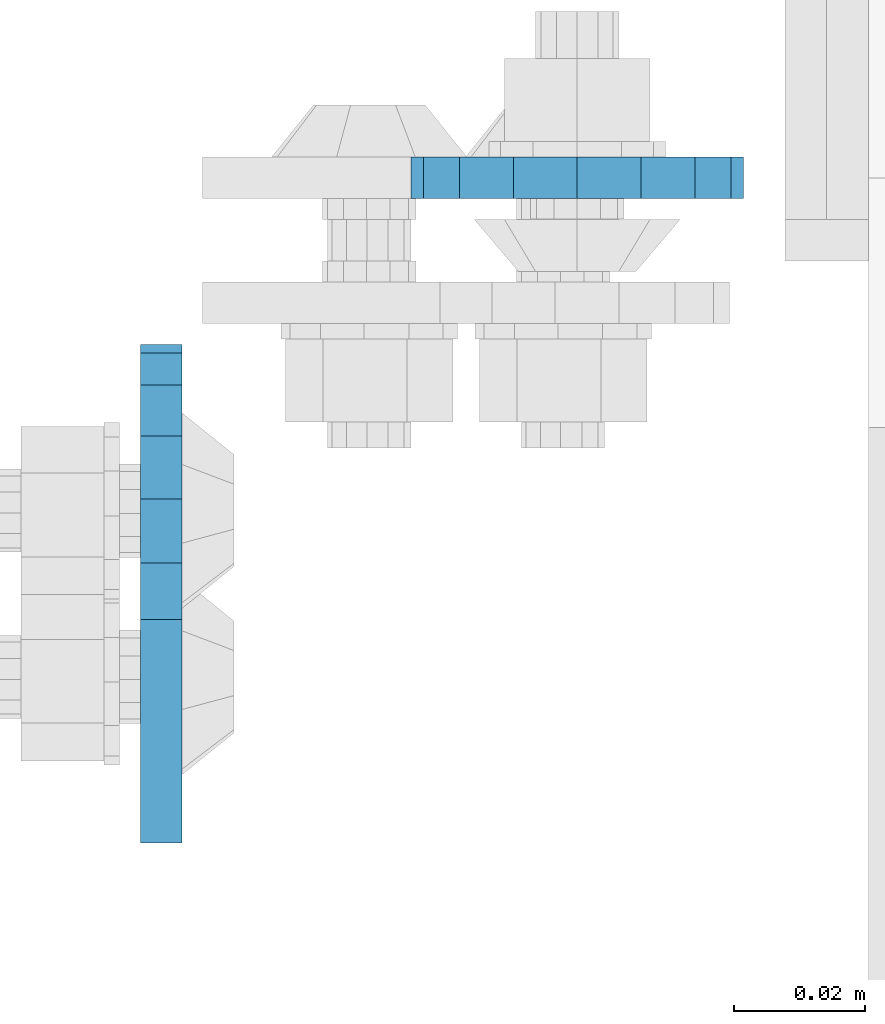
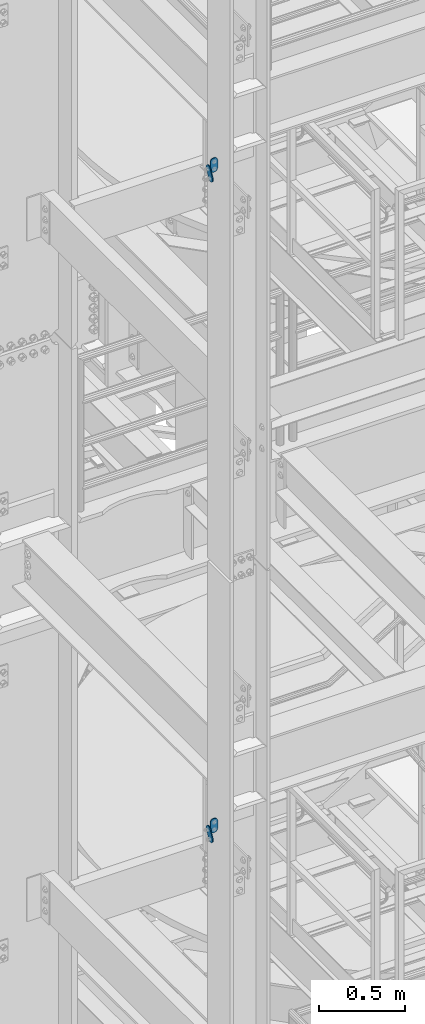
# One storey, part 1419 of 1876: 4 plates, 4 elements without a shape of their own.
"""IFC2X3 building model written with IfcOpenShell, lengths in millimetres."""

from ifc_helpers import new_model, si_unit, frame, origin_with_axes, place, context, subcontext, project, spatial, faceted_brep, material, type_object, element, aggregate, save


model = new_model("IFC2X3")

# Units and contexts
model_context = context("Model", 3, precision=1e-05, world=origin_with_axes())
body_context = subcontext(model_context, "Body", "Model", "MODEL_VIEW")
ifc_project = project(units=[si_unit("LENGTHUNIT", "METRE", prefix="MILLI"), si_unit("AREAUNIT", "SQUARE_METRE"), si_unit("VOLUMEUNIT", "CUBIC_METRE"), si_unit("MASSUNIT", "GRAM", prefix="KILO"), si_unit("TIMEUNIT", "SECOND"), si_unit("PLANEANGLEUNIT", "RADIAN"), si_unit("SOLIDANGLEUNIT", "STERADIAN"), si_unit("THERMODYNAMICTEMPERATUREUNIT", "DEGREE_CELSIUS"), si_unit("LUMINOUSINTENSITYUNIT", "LUMEN")], contexts=[model_context])

# Site, building, storey
site_placement = place(None, origin_with_axes())
site = spatial("IfcSite", under=ifc_project, at=site_placement, CompositionType="ELEMENT")
building_placement = place(site_placement, origin_with_axes())
building = spatial("IfcBuilding", under=site, at=building_placement, Name="Undefined", CompositionType="ELEMENT")
storey_placement = place(building_placement, origin_with_axes())
storey = spatial("IfcBuildingStorey", under=building, at=storey_placement, Name="Undefined", CompositionType="ELEMENT", Elevation=0.0)

# Assembly, plate
assembly_1_placement = place(storey_placement, origin_with_axes())
assembly_1 = element("IfcElementAssembly", 1, at=assembly_1_placement, inside=storey, Name="PLATE", AssemblyPlace="NOTDEFINED", PredefinedType="RIGID_FRAME")
ifc_material = material(Name="STEEL/A36")
plate_type = type_object("IfcPlateType", PredefinedType="NOTDEFINED")
plate_1_placement = place(assembly_1_placement, frame((-361.949999934441, -7404.11120707317, 17716.5), z_axis=(1.0, 0.0, 0.0), x_axis=(0.0, 0.0, -1.0)))
plate_1 = element("IfcPlate", 2, at=plate_1_placement, type_object=plate_type, material=ifc_material, Name="PLATE", context=body_context, shape_type="Brep", body=[
    faceted_brep([(-8.59611645864788e-07, -3.17499999999654, 25.3999987589127), (1.93345873884391, -3.17499999999382, 35.1201580589886), (1.93345873884391, 3.17500000000564, 35.1201580589886), (-8.59611645864788e-07, 3.17500000000382, 25.3999987589132), (7.43948648259902, -3.17499999999109, 43.3605112870105), (7.43948648259902, 3.17500000000928, 43.3605112870105), (15.6798395242777, -3.17499999998654, 48.8665393096448), (15.6798395242777, 3.17500000001382, 48.8665393096448), (25.3999987589095, -3.17499999998199, 50.7999992370592), (25.3999987589095, 3.17500000001837, 50.7999992370592), (76.1999988555108, -3.17500000000018, 50.7999992370601), (76.1999988555108, 3.17500000000018, 50.7999992370601), (85.9201578916036, -3.17500000000018, 48.8665393918844), (85.9201578916036, 3.17500000000018, 48.8665393918844), (94.1605108279182, -3.17500000000018, 43.3605115909282), (94.1605108279182, 3.17500000000018, 43.3605115909282), (99.6665386288878, -3.17500000000018, 35.1201586546208), (99.6665386288878, 3.17500000000018, 35.1201586546208), (101.599998474081, -3.17500000000018, 25.3999996185719), (101.599998474081, 3.17500000000018, 25.3999996185719), (99.6665386289205, -3.17500000000018, 15.679840582484), (99.6665386289205, 3.17500000000018, 15.679840582484), (94.1605108279837, -3.17500000000018, 7.43948764617841), (94.1605108279837, 3.17500000000018, 7.43948764617841), (85.9201578916873, -3.17500000000018, 1.93345984522131), (85.9201578916873, 3.17500000000018, 1.93345984522131), (76.1999988556054, -3.17500000000018, 4.17230694438331e-11), (76.1999988556054, 3.17500000000018, 4.17230694438331e-11), (25.399998758905, -3.17499999999018, -8.64019966684282e-12), (25.399998758905, 3.17500000001019, -8.64019966684282e-12), (15.679839921364, -3.17499999999382, 1.9334597629304), (15.679839921364, 3.17500000000655, 1.9334597629304), (7.43948709043525, -3.17499999999654, 7.43948734220839), (7.43948709043525, 3.17500000000382, 7.43948734220885), (1.93345923228208, -3.17499999999654, 15.6798399868012), (1.93345923228208, 3.17500000000291, 15.6798399868012)], [[[0, 1, 2, 3]], [[1, 4, 5, 2]], [[4, 6, 7, 5]], [[6, 8, 9, 7]], [[8, 10, 11, 9]], [[10, 12, 13, 11]], [[12, 14, 15, 13]], [[14, 16, 17, 15]], [[16, 18, 19, 17]], [[18, 20, 21, 19]], [[20, 22, 23, 21]], [[22, 24, 25, 23]], [[24, 26, 27, 25]], [[26, 28, 29, 27]], [[28, 30, 31, 29]], [[30, 32, 33, 31]], [[32, 34, 35, 33]], [[34, 0, 3, 35]], [[5, 7, 9, 11, 13, 15, 17, 19, 21, 23, 25, 27, 29, 31, 33, 35, 3, 2]], [[34, 32, 30, 28, 26, 24, 22, 20, 18, 16, 14, 12, 10, 8, 6, 4, 1, 0]]]),
])
aggregate(assembly_1, [plate_1])

assembly_2_placement = place(storey_placement, origin_with_axes())
assembly_2 = element("IfcElementAssembly", 3, at=assembly_2_placement, inside=storey, Name="PLATE", AssemblyPlace="NOTDEFINED", PredefinedType="RIGID_FRAME")
plate_2_placement = place(assembly_2_placement, frame((-361.949999934442, -7404.11120707317, 13030.2), z_axis=(1.0, 0.0, 0.0), x_axis=(0.0, 0.0, -1.0)))
plate_2 = element("IfcPlate", 4, at=plate_2_placement, type_object=plate_type, material=ifc_material, Name="PLATE", context=body_context, shape_type="Brep", body=[
    faceted_brep([(-8.59611645864788e-07, -3.17499999999654, 25.3999987589127), (1.93345873884391, -3.17499999999382, 35.1201580589886), (1.93345873884391, 3.17500000000564, 35.1201580589886), (-8.59611645864788e-07, 3.17500000000382, 25.3999987589132), (7.43948648259902, -3.17499999999109, 43.3605112870105), (7.43948648259902, 3.17500000000928, 43.3605112870105), (15.6798395242777, -3.17499999998654, 48.8665393096448), (15.6798395242777, 3.17500000001382, 48.8665393096448), (25.3999987589095, -3.17499999998199, 50.7999992370592), (25.3999987589095, 3.17500000001837, 50.7999992370592), (76.1999988555108, -3.17500000000018, 50.7999992370601), (76.1999988555108, 3.17500000000018, 50.7999992370601), (85.9201578916036, -3.17500000000018, 48.8665393918844), (85.9201578916036, 3.17500000000018, 48.8665393918844), (94.1605108279182, -3.17500000000018, 43.3605115909282), (94.1605108279182, 3.17500000000018, 43.3605115909282), (99.6665386288878, -3.17500000000018, 35.1201586546208), (99.6665386288878, 3.17500000000018, 35.1201586546208), (101.599998474081, -3.17500000000018, 25.3999996185719), (101.599998474081, 3.17500000000018, 25.3999996185719), (99.6665386289205, -3.17500000000018, 15.679840582484), (99.6665386289205, 3.17500000000018, 15.679840582484), (94.1605108279837, -3.17500000000018, 7.43948764617841), (94.1605108279837, 3.17500000000018, 7.43948764617841), (85.9201578916873, -3.17500000000018, 1.93345984522131), (85.9201578916873, 3.17500000000018, 1.93345984522131), (76.1999988556054, -3.17500000000018, 4.17230694438331e-11), (76.1999988556054, 3.17500000000018, 4.17230694438331e-11), (25.399998758905, -3.17499999999018, -8.64019966684282e-12), (25.399998758905, 3.17500000001019, -8.64019966684282e-12), (15.679839921364, -3.17499999999382, 1.9334597629304), (15.679839921364, 3.17500000000655, 1.9334597629304), (7.43948709043525, -3.17499999999654, 7.43948734220839), (7.43948709043525, 3.17500000000382, 7.43948734220885), (1.93345923228208, -3.17499999999654, 15.6798399868012), (1.93345923228208, 3.17500000000291, 15.6798399868012)], [[[0, 1, 2, 3]], [[1, 4, 5, 2]], [[4, 6, 7, 5]], [[6, 8, 9, 7]], [[8, 10, 11, 9]], [[10, 12, 13, 11]], [[12, 14, 15, 13]], [[14, 16, 17, 15]], [[16, 18, 19, 17]], [[18, 20, 21, 19]], [[20, 22, 23, 21]], [[22, 24, 25, 23]], [[24, 26, 27, 25]], [[26, 28, 29, 27]], [[28, 30, 31, 29]], [[30, 32, 33, 31]], [[32, 34, 35, 33]], [[34, 0, 3, 35]], [[5, 7, 9, 11, 13, 15, 17, 19, 21, 23, 25, 27, 29, 31, 33, 35, 3, 2]], [[34, 32, 30, 28, 26, 24, 22, 20, 18, 16, 14, 12, 10, 8, 6, 4, 1, 0]]]),
])
aggregate(assembly_2, [plate_2])

assembly_3_placement = place(storey_placement, origin_with_axes())
assembly_3 = element("IfcElementAssembly", 5, at=assembly_3_placement, inside=storey, Name="PLATE", AssemblyPlace="NOTDEFINED", PredefinedType="RIGID_FRAME")
plate_3_placement = place(assembly_3_placement, frame((-400.038795215647, -7466.25922341129, 17725.1776774809), z_axis=(0.0, 0.894427191199917, -0.447213595099955), x_axis=(0.0, -0.447213595099955, -0.894427191199917)))
plate_3 = element("IfcPlate", 6, at=plate_3_placement, type_object=plate_type, material=ifc_material, Name="PLATE", context=body_context, shape_type="Brep", body=[
    faceted_brep([(-8.59611645864788e-07, -3.17499999999654, 25.3999987589127), (1.93345873884391, -3.17499999999382, 35.1201580589886), (1.93345873884391, 3.17500000000564, 35.1201580589886), (-8.59611645864788e-07, 3.17500000000382, 25.3999987589132), (7.43948648259902, -3.17499999999109, 43.3605112870105), (7.43948648259902, 3.17500000000928, 43.3605112870105), (15.6798395242777, -3.17499999998654, 48.8665393096448), (15.6798395242777, 3.17500000001382, 48.8665393096448), (25.3999987589095, -3.17499999998199, 50.7999992370592), (25.3999987589095, 3.17500000001837, 50.7999992370592), (82.196130752618, -3.17499999998381, 50.7999992370605), (82.196130752618, 3.17500000001655, 50.7999992370642), (91.9162897887145, -3.17499999997926, 48.8665393918873), (91.9162897887145, 3.1750000000211, 48.8665393918909), (100.156642725027, -3.17499999997472, 43.3605115909359), (100.156642725027, 3.17500000002565, 43.3605115909395), (105.662670525982, -3.17499999997108, 35.1201586546285), (105.662670525986, 3.17500000002929, 35.1201586546358), (107.596130371159, -3.17499999996744, 25.3999996185757), (107.596130371159, 3.17500000003292, 25.3999996185794), (105.662670525981, -3.17499999996471, 15.6798405824902), (105.662670525981, 3.17500000003565, 15.6798405824939), (100.156642725024, -3.17499999996471, 7.43948764618654), (100.156642725025, 3.17500000003565, 7.43948764619017), (91.9162897887127, -3.17499999996562, 1.93345984522784), (91.9162897887127, 3.17500000003474, 1.93345984523148), (82.196130752618, -3.17499999996835, 4.54747350886464e-11), (82.196130752618, 3.1750000000311, 4.91127138957381e-11), (25.399998758905, -3.17499999999018, -8.64019966684282e-12), (25.399998758905, 3.17500000001019, -8.64019966684282e-12), (15.679839921364, -3.17499999999382, 1.9334597629304), (15.679839921364, 3.17500000000655, 1.9334597629304), (7.43948709043525, -3.17499999999654, 7.43948734220839), (7.43948709043525, 3.17500000000382, 7.43948734220885), (1.93345923228208, -3.17499999999654, 15.6798399868012), (1.93345923228208, 3.17500000000291, 15.6798399868012)], [[[0, 1, 2, 3]], [[1, 4, 5, 2]], [[4, 6, 7, 5]], [[6, 8, 9, 7]], [[8, 10, 11, 9]], [[10, 12, 13, 11]], [[12, 14, 15, 13]], [[14, 16, 17, 15]], [[16, 18, 19, 17]], [[18, 20, 21, 19]], [[20, 22, 23, 21]], [[22, 24, 25, 23]], [[24, 26, 27, 25]], [[26, 28, 29, 27]], [[28, 30, 31, 29]], [[30, 32, 33, 31]], [[32, 34, 35, 33]], [[34, 0, 3, 35]], [[5, 7, 9, 11, 13, 15, 17, 19, 21, 23, 25, 27, 29, 31, 33, 35, 3, 2]], [[34, 32, 30, 28, 26, 24, 22, 20, 18, 16, 14, 12, 10, 8, 6, 4, 1, 0]]]),
])
aggregate(assembly_3, [plate_3])

assembly_4_placement = place(storey_placement, origin_with_axes())
assembly_4 = element("IfcElementAssembly", 7, at=assembly_4_placement, inside=storey, Name="PLATE", AssemblyPlace="NOTDEFINED", PredefinedType="RIGID_FRAME")
plate_4_placement = place(assembly_4_placement, frame((-400.038795215648, -7466.25922341129, 13038.8776774809), z_axis=(0.0, 0.894427191199917, -0.447213595099955), x_axis=(0.0, -0.447213595099955, -0.894427191199917)))
plate_4 = element("IfcPlate", 8, at=plate_4_placement, type_object=plate_type, material=ifc_material, Name="PLATE", context=body_context, shape_type="Brep", body=[
    faceted_brep([(-8.59611645864788e-07, -3.17499999999654, 25.3999987589127), (1.93345873884391, -3.17499999999382, 35.1201580589886), (1.93345873884391, 3.17500000000564, 35.1201580589886), (-8.59611645864788e-07, 3.17500000000382, 25.3999987589132), (7.43948648259902, -3.17499999999109, 43.3605112870105), (7.43948648259902, 3.17500000000928, 43.3605112870105), (15.6798395242777, -3.17499999998654, 48.8665393096448), (15.6798395242777, 3.17500000001382, 48.8665393096448), (25.3999987589095, -3.17499999998199, 50.7999992370592), (25.3999987589095, 3.17500000001837, 50.7999992370592), (82.196130752618, -3.17499999998381, 50.7999992370605), (82.196130752618, 3.17500000001655, 50.7999992370642), (91.9162897887145, -3.17499999997926, 48.8665393918873), (91.9162897887145, 3.1750000000211, 48.8665393918909), (100.156642725027, -3.17499999997472, 43.3605115909359), (100.156642725027, 3.17500000002565, 43.3605115909395), (105.662670525982, -3.17499999997108, 35.1201586546285), (105.662670525986, 3.17500000002929, 35.1201586546358), (107.596130371159, -3.17499999996744, 25.3999996185757), (107.596130371159, 3.17500000003292, 25.3999996185794), (105.662670525981, -3.17499999996471, 15.6798405824902), (105.662670525981, 3.17500000003565, 15.6798405824939), (100.156642725024, -3.17499999996471, 7.43948764618654), (100.156642725025, 3.17500000003565, 7.43948764619017), (91.9162897887127, -3.17499999996562, 1.93345984522784), (91.9162897887127, 3.17500000003474, 1.93345984523148), (82.196130752618, -3.17499999996835, 4.54747350886464e-11), (82.196130752618, 3.1750000000311, 4.91127138957381e-11), (25.399998758905, -3.17499999999018, -8.64019966684282e-12), (25.399998758905, 3.17500000001019, -8.64019966684282e-12), (15.679839921364, -3.17499999999382, 1.9334597629304), (15.679839921364, 3.17500000000655, 1.9334597629304), (7.43948709043525, -3.17499999999654, 7.43948734220839), (7.43948709043525, 3.17500000000382, 7.43948734220885), (1.93345923228208, -3.17499999999654, 15.6798399868012), (1.93345923228208, 3.17500000000291, 15.6798399868012)], [[[0, 1, 2, 3]], [[1, 4, 5, 2]], [[4, 6, 7, 5]], [[6, 8, 9, 7]], [[8, 10, 11, 9]], [[10, 12, 13, 11]], [[12, 14, 15, 13]], [[14, 16, 17, 15]], [[16, 18, 19, 17]], [[18, 20, 21, 19]], [[20, 22, 23, 21]], [[22, 24, 25, 23]], [[24, 26, 27, 25]], [[26, 28, 29, 27]], [[28, 30, 31, 29]], [[30, 32, 33, 31]], [[32, 34, 35, 33]], [[34, 0, 3, 35]], [[5, 7, 9, 11, 13, 15, 17, 19, 21, 23, 25, 27, 29, 31, 33, 35, 3, 2]], [[34, 32, 30, 28, 26, 24, 22, 20, 18, 16, 14, 12, 10, 8, 6, 4, 1, 0]]]),
])
aggregate(assembly_4, [plate_4])

save(model, "model.ifc")
